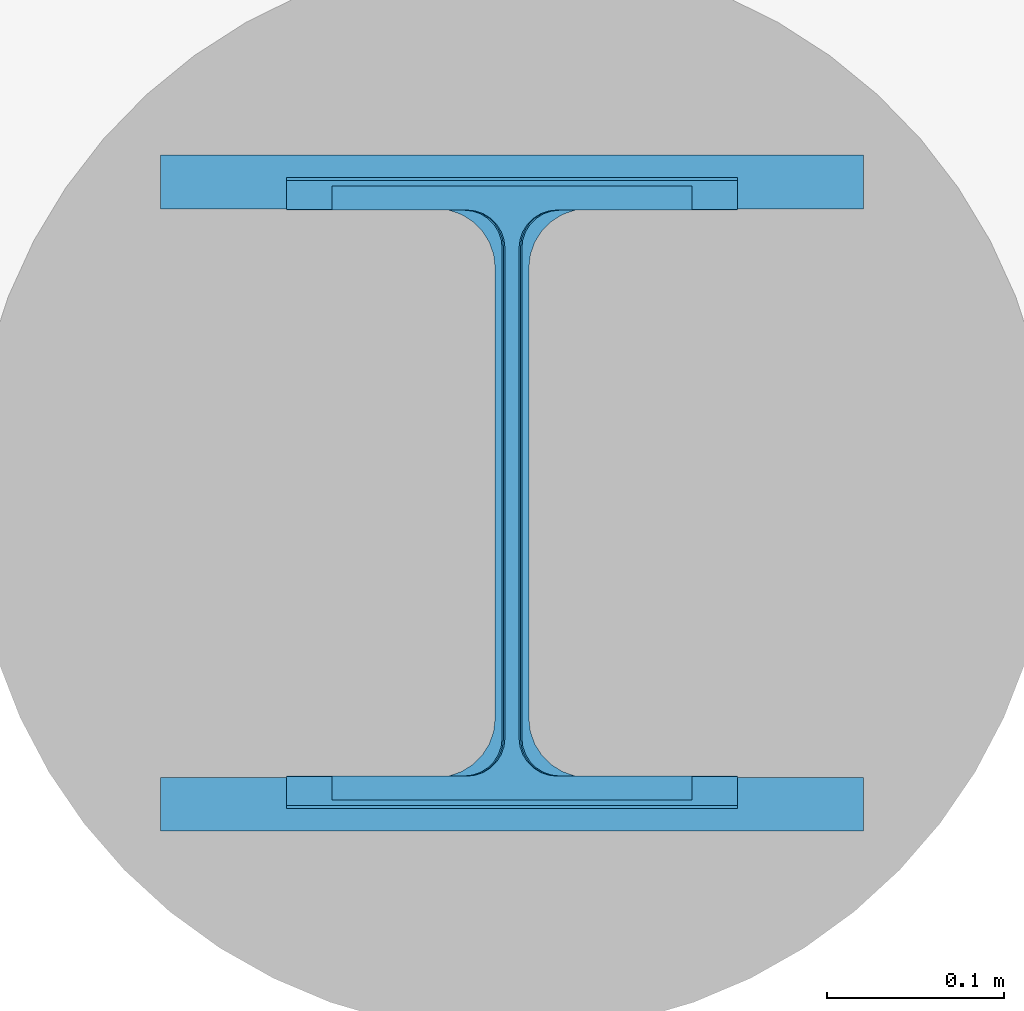
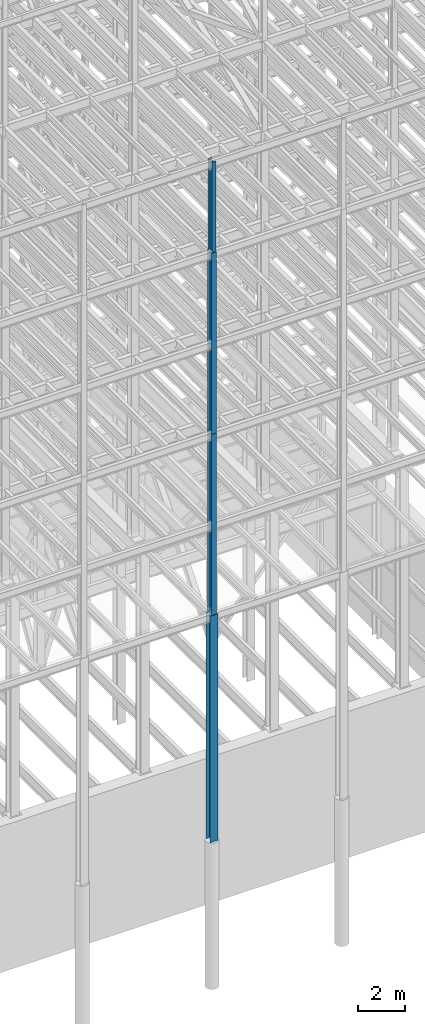
# One storey, part 72 of 150: 4 columns.
"""IFC2X3 building model written with IfcOpenShell, lengths in millimetres."""

import ifcopenshell
import ifcopenshell.guid

model = None  # the IFC model being written
_history = None  # IfcOwnerHistory: only IFC2X3 demands one
_inside = {}  # id of a spatial element -> (the spatial element, [elements in it])
_under = {}  # id of a project, library or spatial element -> (it, [spatial elements below it])
_declared = {}  # id of a project -> (the project, [libraries it declares])
_typed = {}  # id of a type object -> (the type object, [elements of that type])
_made_of = {}  # id of a material, layer set ... -> (it, [elements and type objects made of it])


def new_model(schema):
    """Start an empty IFC model of exactly this schema.

    Asked for "IFC4X3", IfcOpenShell would pick the latest addendum, in which some entities
    have other attributes; the version numbers below select the first issue.
    IFC2X3 requires an IfcOwnerHistory on every rooted entity: one is made here for all.
    """
    global model, _history
    if schema == "IFC4X3":
        model = ifcopenshell.file(schema_version=(4, 3, 0, 0))
    else:
        model = ifcopenshell.file(schema=schema)
    _inside.clear()
    _under.clear()
    _declared.clear()
    _typed.clear()
    _made_of.clear()
    _history = None
    if model.schema == "IFC2X3":
        org = make("IfcOrganization", Name="unknown")
        user = make(
            "IfcPersonAndOrganization",
            ThePerson=make("IfcPerson", FamilyName="unknown"),
            TheOrganization=org,
        )
        app = make(
            "IfcApplication",
            ApplicationDeveloper=org,
            Version="unknown",
            ApplicationFullName="unknown",
            ApplicationIdentifier="unknown",
        )
        _history = make(
            "IfcOwnerHistory",
            OwningUser=user,
            OwningApplication=app,
            ChangeAction="ADDED",
            CreationDate=0,
        )
    return model


def make(cls, **values):
    """One entity of the class cls with the attributes given. An attribute that is None is left unset."""
    return model.create_entity(
        cls, **{name: value for name, value in values.items() if value is not None}
    )


def rooted(cls, **values):
    """An entity with a GlobalId (a new one), such as an element, a storey or a relation."""
    return make(cls, GlobalId=ifcopenshell.guid.new(), OwnerHistory=_history, **values)


def si_unit(unit_type, name, prefix=None):
    """IfcSIUnit, for example si_unit("LENGTHUNIT", "METRE", prefix="MILLI")."""
    return make("IfcSIUnit", UnitType=unit_type, Prefix=prefix, Name=name)


def assignment(units):
    """IfcUnitAssignment: the units of a project."""
    return None if units is None else make("IfcUnitAssignment", Units=units)


def point(xyz):
    """IfcCartesianPoint."""
    return None if xyz is None else make("IfcCartesianPoint", Coordinates=xyz)


def direction(xyz):
    """IfcDirection."""
    return None if xyz is None else make("IfcDirection", DirectionRatios=xyz)


def frame(location, z_axis=None, x_axis=None):
    """IfcAxis2Placement3D, a coordinate frame: its origin and axes. An axis left out is left unset."""
    return make(
        "IfcAxis2Placement3D",
        Location=point(location),
        Axis=direction(z_axis),
        RefDirection=direction(x_axis),
    )


def frame_2d(location, x_axis=None):
    """IfcAxis2Placement2D, a coordinate frame in the plane: its origin and x axis."""
    return make(
        "IfcAxis2Placement2D", Location=point(location), RefDirection=direction(x_axis)
    )


def origin_with_axes():
    """The frame at (0, 0, 0) with the z axis (0, 0, 1) and the x axis (1, 0, 0) written out."""
    return frame((0.0, 0.0, 0.0), z_axis=(0.0, 0.0, 1.0), x_axis=(1.0, 0.0, 0.0))


def origin_2d_with_axis():
    """The frame at (0, 0) in the plane with the x axis (1, 0) written out."""
    return frame_2d((0.0, 0.0), x_axis=(1.0, 0.0))


def place(relative_to, where):
    """IfcLocalPlacement: puts the frame where relative to a parent placement (None: the world)."""
    return make(
        "IfcLocalPlacement", PlacementRelTo=relative_to, RelativePlacement=where
    )


def context(
    kind, dimensions, precision=None, world=None, true_north=None, identifier=None
):
    """IfcGeometricRepresentationContext, for example the 3D "Model" context."""
    return make(
        "IfcGeometricRepresentationContext",
        ContextIdentifier=identifier,
        ContextType=kind,
        CoordinateSpaceDimension=dimensions,
        Precision=precision,
        WorldCoordinateSystem=world,
        TrueNorth=true_north,
    )


def subcontext(parent, identifier, kind, view, scale=None):
    """IfcGeometricRepresentationSubContext, for example "Body" below "Model"."""
    return make(
        "IfcGeometricRepresentationSubContext",
        ContextIdentifier=identifier,
        ContextType=kind,
        ParentContext=parent,
        TargetScale=scale,
        TargetView=view,
    )


def project(units=None, contexts=None):
    """IfcProject with its units and contexts."""
    return rooted(
        "IfcProject",
        Name="project",
        RepresentationContexts=contexts,
        UnitsInContext=assignment(units),
    )


def spatial(cls, under=None, at=None, **own):
    """A site, building, storey or space (cls), placed at a placement, below another one or the project."""
    s = rooted(cls, ObjectPlacement=at, **own)
    if under is not None:
        _under.setdefault(under.id(), (under, []))[1].append(s)
    return s


def profile(cls, at=None, kind="AREA", **sizes):
    """A parametric profile (cls). Its sizes go by their IFC names, for example OverallWidth=200.0."""
    return make(cls, ProfileType=kind, Position=at, **sizes)


def i_section(**sizes):
    """IfcIShapeProfileDef."""
    return profile("IfcIShapeProfileDef", **sizes)


def extrude(swept, where, along, depth):
    """IfcExtrudedAreaSolid: the profile swept, set in the frame where, extruded along a direction by depth."""
    return make(
        "IfcExtrudedAreaSolid",
        SweptArea=swept,
        Position=where,
        ExtrudedDirection=direction(along),
        Depth=depth,
    )


def shape(context_of_items, identifier, shape_type, items):
    """IfcShapeRepresentation: the items that make up one representation, for example the "Body"."""
    return make(
        "IfcShapeRepresentation",
        ContextOfItems=context_of_items,
        RepresentationIdentifier=identifier,
        RepresentationType=shape_type,
        Items=items,
    )


def material(Name=None, Category=None):
    """IfcMaterial."""
    return make("IfcMaterial", Name=Name, Category=Category)


def made_of(thing, what):
    """Note that an element or type object is made of a material, layer set ...; save() writes the relation."""
    if what is not None:
        _made_of.setdefault(what.id(), (what, []))[1].append(thing)
    return thing


def type_object(cls, material=None, **own):
    """A type object (cls), such as IfcWallType, which elements share."""
    return made_of(rooted(cls, **own), material)


def element(
    cls,
    number,
    at=None,
    inside=None,
    cuts=None,
    type_object=None,
    material=None,
    context=None,
    identifier="Body",
    shape_type=None,
    held_by="IfcProductDefinitionShape",
    body=None,
    shapes=None,
    **own,
):
    """One element of the class cls, such as IfcWall. Its Tag is "e" and its number.

    at: its placement. inside: the storey or other place that contains it. cuts: it is an
    opening in that element (IfcRelVoidsElement). A single representation is given by context,
    identifier, shape_type and body (its items); several are given by shapes. held_by: the class
    of the entity that holds the representations. save() writes the other relations.
    """
    e = rooted(cls, Tag="e%d" % number, ObjectPlacement=at, **own)
    if body is not None:
        shapes = [shape(context, identifier, shape_type, body)]
    if shapes is not None:
        e.Representation = make(held_by, Representations=shapes)
    if inside is not None:
        _inside.setdefault(inside.id(), (inside, []))[1].append(e)
    if cuts is not None:
        rooted(
            "IfcRelVoidsElement", RelatingBuildingElement=cuts, RelatedOpeningElement=e
        )
    if type_object is not None:
        _typed.setdefault(type_object.id(), (type_object, []))[1].append(e)
    return made_of(e, material)


def aggregate(whole, parts):
    """IfcRelAggregates: a whole, such as a stair, and the parts it consists of."""
    return rooted("IfcRelAggregates", RelatingObject=whole, RelatedObjects=parts)


def save(model, path):
    """Write the relations noted so far, then the file.

    IfcRelAggregates (storeys below a building ...), IfcRelContainedInSpatialStructure (elements
    in a storey), IfcRelDefinesByType, IfcRelAssociatesMaterial and IfcRelDeclares: one each for
    every whole, place, type object, material and project.
    """
    for whole, parts in _under.values():
        aggregate(whole, parts)
    for where, things in _inside.values():
        rooted(
            "IfcRelContainedInSpatialStructure",
            RelatedElements=things,
            RelatingStructure=where,
        )
    for kind, things in _typed.values():
        rooted("IfcRelDefinesByType", RelatedObjects=things, RelatingType=kind)
    for what, things in _made_of.values():
        rooted("IfcRelAssociatesMaterial", RelatedObjects=things, RelatingMaterial=what)
    for by, libraries in _declared.values():
        rooted("IfcRelDeclares", RelatingContext=by, RelatedDefinitions=libraries)
    model.write(path)


model = new_model("IFC2X3")

# Units and contexts
model_context = context("Model", 3, precision=1e-05, world=origin_with_axes())
body_context = subcontext(model_context, "Body", "Model", "MODEL_VIEW")
ifc_project = project(units=[si_unit("LENGTHUNIT", "METRE", prefix="MILLI"), si_unit("AREAUNIT", "SQUARE_METRE"), si_unit("VOLUMEUNIT", "CUBIC_METRE"), si_unit("MASSUNIT", "GRAM", prefix="KILO"), si_unit("TIMEUNIT", "SECOND"), si_unit("PLANEANGLEUNIT", "RADIAN"), si_unit("SOLIDANGLEUNIT", "STERADIAN"), si_unit("THERMODYNAMICTEMPERATUREUNIT", "DEGREE_CELSIUS"), si_unit("LUMINOUSINTENSITYUNIT", "LUMEN")], contexts=[model_context])

# Site, building, storey
site_placement = place(None, origin_with_axes())
site = spatial("IfcSite", under=ifc_project, at=site_placement, CompositionType="ELEMENT")
building_placement = place(site_placement, origin_with_axes())
building = spatial("IfcBuilding", under=site, at=building_placement, Name="Undefined", CompositionType="ELEMENT")
storey_placement = place(building_placement, origin_with_axes())
storey = spatial("IfcBuildingStorey", under=building, at=storey_placement, Name="Undefined", CompositionType="ELEMENT", Elevation=0.0)

# Columns
ifc_material = material(Name="STEEL/A992")
column_type_1 = type_object("IfcColumnType", Name="W14X43", PredefinedType="NOTDEFINED")
column_1_placement = place(storey_placement, frame((69392.8, 3454.4, 54482.99811024), z_axis=(0.0, 0.0, 1.0), x_axis=(1.0, 0.0, 0.0)))
element("IfcColumn", 1, at=column_1_placement, inside=storey, type_object=column_type_1, material=ifc_material, Name="COLUMN", ObjectType="W14X43", context=body_context, shape_type="SweptSolid", body=[
    extrude(i_section(OverallWidth=203.2, OverallDepth=346.075, WebThickness=7.9375, FlangeThickness=13.462, FilletRadius=21.4629, at=origin_2d_with_axis()), frame((0.0, 0.0, 4724.39999999999), z_axis=(0.0, 0.0, -1.0), x_axis=(-1.0, 0.0, 0.0)), (0.0, 0.0, 1.0), 4724.4),
])
column_type_2 = type_object("IfcColumnType", Name="W14X61", PredefinedType="NOTDEFINED")
column_2_placement = place(storey_placement, frame((69392.8, 3454.4, 45034.19811024), z_axis=(0.0, 0.0, 1.0), x_axis=(1.0, 0.0, 0.0)))
element("IfcColumn", 2, at=column_2_placement, inside=storey, type_object=column_type_2, material=ifc_material, Name="COLUMN", ObjectType="W14X61", context=body_context, shape_type="SweptSolid", body=[
    extrude(i_section(OverallWidth=254.0, OverallDepth=352.425, WebThickness=9.5249, FlangeThickness=16.383, FilletRadius=21.717, at=origin_2d_with_axis()), frame((0.0, 0.0, 9448.8), z_axis=(0.0, 0.0, -1.0), x_axis=(-1.0, 0.0, 0.0)), (0.0, 0.0, 1.0), 9448.8),
])
column_type_3 = type_object("IfcColumnType", Name="W14X68", PredefinedType="NOTDEFINED")
column_3_placement = place(storey_placement, frame((69392.8, 3454.4, 35585.39811024), z_axis=(0.0, 0.0, 1.0), x_axis=(1.0, 0.0, 0.0)))
element("IfcColumn", 3, at=column_3_placement, inside=storey, type_object=column_type_3, material=ifc_material, Name="COLUMN", ObjectType="W14X68", context=body_context, shape_type="SweptSolid", body=[
    extrude(i_section(OverallWidth=254.0, OverallDepth=355.6, WebThickness=11.1125, FlangeThickness=18.288, FilletRadius=21.3994, at=origin_2d_with_axis()), frame((0.0, 0.0, 9448.8), z_axis=(0.0, 0.0, -1.0), x_axis=(-1.0, 0.0, 0.0)), (0.0, 0.0, 1.0), 9448.8),
])
column_type_4 = type_object("IfcColumnType", Name="W14X159", PredefinedType="NOTDEFINED")
column_4_placement = place(storey_placement, frame((69392.8, 3454.4, 23774.39811024), z_axis=(0.0, 0.0, 1.0), x_axis=(1.0, 0.0, 0.0)))
element("IfcColumn", 4, at=column_4_placement, inside=storey, type_object=column_type_4, material=ifc_material, Name="COLUMN", ObjectType="W14X159", context=body_context, shape_type="SweptSolid", body=[
    extrude(i_section(OverallWidth=396.24, OverallDepth=381.0, WebThickness=19.0499, FlangeThickness=30.226, FilletRadius=33.2739, at=origin_2d_with_axis()), frame((0.0, 0.0, 11810.9988189), z_axis=(0.0, 0.0, -1.0), x_axis=(-1.0, 0.0, 0.0)), (0.0, 0.0, 1.0), 11810.9988189),
])

save(model, "model.ifc")
